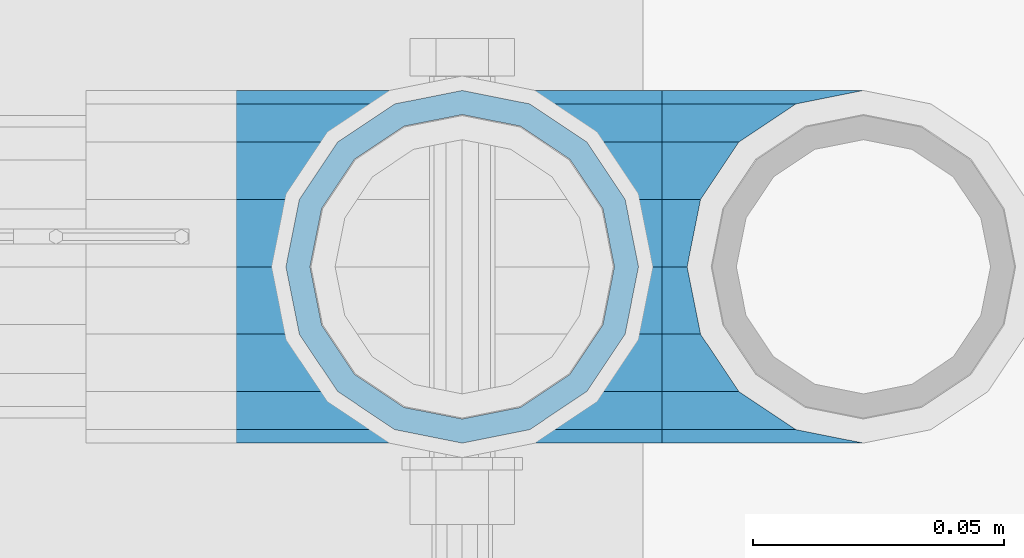
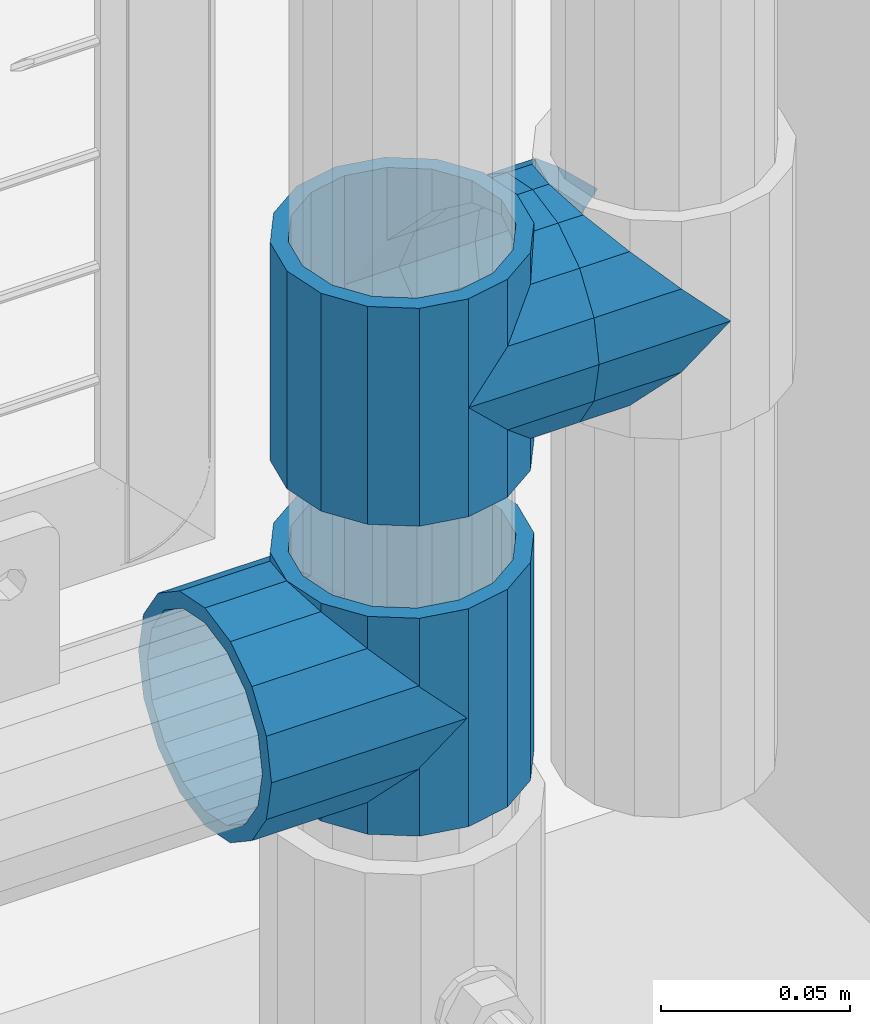
# One storey, part 173 of 257: 5 beams.
"""IFC2X3 building model written with IfcOpenShell, lengths in millimetres."""

from ifc_helpers import new_model, si_unit, frame, origin_with_axes, place, context, subcontext, project, spatial, faceted_brep, material, type_object, element, save


model = new_model("IFC2X3")

# Units and contexts
model_context = context("Model", 3, precision=1e-05, world=origin_with_axes())
body_context = subcontext(model_context, "Body", "Model", "MODEL_VIEW")
ifc_project = project(units=[si_unit("LENGTHUNIT", "METRE", prefix="MILLI"), si_unit("AREAUNIT", "SQUARE_METRE"), si_unit("VOLUMEUNIT", "CUBIC_METRE"), si_unit("MASSUNIT", "GRAM", prefix="KILO"), si_unit("TIMEUNIT", "SECOND"), si_unit("PLANEANGLEUNIT", "RADIAN"), si_unit("SOLIDANGLEUNIT", "STERADIAN"), si_unit("THERMODYNAMICTEMPERATUREUNIT", "DEGREE_CELSIUS"), si_unit("LUMINOUSINTENSITYUNIT", "LUMEN")], contexts=[model_context])

# Site, building, storey
site_placement = place(None, origin_with_axes())
site = spatial("IfcSite", under=ifc_project, at=site_placement, CompositionType="ELEMENT")
building_placement = place(site_placement, origin_with_axes())
building = spatial("IfcBuilding", under=site, at=building_placement, Name="Standard", CompositionType="ELEMENT")
storey_placement = place(building_placement, origin_with_axes())
storey = spatial("IfcBuildingStorey", under=building, at=storey_placement, Name="Undefined", CompositionType="ELEMENT", Elevation=0.0)

# Beams
ifc_material = material(Name="Misc_Undefined")
beam_type = type_object("IfcBeamType", PredefinedType="NOTDEFINED")
beam_1_placement = place(storey_placement, frame((58671.0, 10664.5, 298.670000000001), z_axis=(0.0, 1.0, 0.0), x_axis=(-1.0, 0.0, 0.0)))
element("IfcBeam", 1, at=beam_1_placement, inside=storey, type_object=beam_type, material=ifc_material, context=body_context, shape_type="Brep", body=[
    faceted_brep([(13.4513226476338, -13.4513226476329, -32.4743655677721), (13.4513226476338, 13.4513226476329, -32.4743655677721), (0.0, 0.0, -35.1499999999996), (24.8548033587067, -24.8548033587072, 24.8548033587067), (24.8548033587067, -16.3810424080013, 24.8548033587067), (27.122676859115, -21.4606908090117, 21.4606908090118), (32.4743655677739, -26.8123795176754, 13.4513226476338), (32.4743655677739, -32.4743655677717, 13.4513226476338), (32.8397438117172, -28.0397438117175, 11.6144421722802), (35.1500000000015, -30.35, 0.0), (35.1500000000015, -35.1499999999996, 0.0), (32.8397438117172, -28.0397438117175, -11.6144421722802), (32.4743655677739, -26.8123795176755, -13.4513226476338), (32.4743655677739, -32.4743655677717, -13.4513226476338), (27.1226768591005, -21.4606908090117, -21.4606908090118), (24.8548033587067, -16.3810424080045, -24.8548033587067), (24.8548033587067, -24.8548033587072, -24.8548033587067), (20.0882031229849, -11.6144421722805, -28.0397438117179), (16.6306603983685, 0.0, -30.3500000000004), (20.0882031229849, 11.6144421722805, -28.0397438117179), (24.8548033587067, 16.3810424080013, -24.8548033587067), (24.8548033587067, 24.8548033587072, -24.8548033587067), (32.4743655677739, 26.8123795176754, -13.4513226476338), (32.4743655677739, 32.4743655677717, -13.4513226476338), (27.1226768591005, 21.4606908090117, -21.4606908090118), (35.1500000000015, 30.35, 0.0), (35.1500000000015, 35.15, 0.0), (32.8397438117172, 28.0397438117175, -11.6144421722802), (32.8397438117172, 28.0397438117175, 11.6144421722802), (32.4743655677739, 26.8123795176755, 13.4513226476338), (32.4743655677739, 32.4743655677717, 13.4513226476338), (27.122676859115, 21.4606908090117, 21.4606908090118), (24.8548033587067, 16.3810424080013, 24.8548033587067), (24.8548033587067, 24.8548033587072, 24.8548033587067), (0.0, 0.0, 35.1499999999996), (13.4513226476338, 13.4513226476329, 32.4743655677721), (13.4513226476338, -13.4513226476329, 32.4743655677721), (20.0882031229849, 11.6144421722805, 28.0397438117179), (16.6306603983758, 0.0, 30.3500000000004), (20.0882031229849, -11.6144421722805, 28.0397438117179), (60.1500000000015, -35.15, 0.0), (60.1500000000015, -32.4743655677717, 13.4513226476338), (60.1500000000015, -24.8548033587072, 24.8548033587067), (60.1500000000015, -13.4513226476329, 32.4743655677721), (60.1500000000015, 0.0, 35.1499999999996), (60.1500000000015, -24.8548033587072, -24.8548033587067), (60.1500000000015, -32.4743655677717, -13.4513226476338), (60.1500000000015, -13.4513226476329, -32.4743655677721), (60.1500000000015, 0.0, -35.1499999999996), (60.1500000000015, 13.4513226476329, -32.4743655677721), (60.1500000000015, 24.8548033587072, -24.8548033587067), (60.1500000000015, 32.4743655677717, -13.4513226476338), (60.1500000000015, 35.15, 0.0), (60.1500000000015, 32.4743655677717, 13.4513226476338), (60.1500000000015, 24.8548033587072, 24.8548033587067), (60.1500000000015, 13.4513226476329, 32.4743655677721), (60.1500000000015, -21.4606908090117, 21.4606908090118), (60.1500000000015, -11.6144421722805, 28.0397438117179), (60.1500000000015, 0.0, 30.3500000000004), (60.1500000000015, 11.6144421722805, 28.0397438117179), (60.1500000000015, 21.4606908090117, 21.4606908090118), (60.1500000000015, 28.0397438117175, 11.6144421722802), (60.1500000000015, 30.35, 0.0), (60.1500000000015, 28.0397438117175, -11.6144421722802), (60.1500000000015, 21.4606908090117, -21.4606908090118), (60.1500000000015, 11.6144421722805, -28.0397438117179), (60.1500000000015, 0.0, -30.3500000000004), (60.1500000000015, -11.6144421722805, -28.0397438117179), (60.1500000000015, -21.4606908090117, -21.4606908090118), (60.1500000000015, -28.0397438117175, -11.6144421722802), (60.1500000000015, -30.35, 0.0), (60.1500000000015, -28.0397438117175, 11.6144421722802)], [[[0, 1, 2]], [[3, 4, 5, 6, 7]], [[7, 6, 8, 9, 10]], [[10, 9, 11, 12, 13]], [[13, 12, 14, 15, 16]], [[16, 15, 17, 18, 19, 20, 21, 1, 0]], [[22, 23, 21, 20, 24]], [[25, 26, 23, 22, 27]], [[28, 29, 30, 26, 25]], [[31, 32, 33, 30, 29]], [[34, 35, 36]], [[36, 35, 33, 32, 37, 38, 39, 4, 3]], [[40, 41, 7, 10]], [[41, 42, 3, 7]], [[42, 43, 36, 3]], [[43, 44, 34, 36]], [[45, 46, 13, 16]], [[47, 45, 16, 0]], [[48, 47, 0, 2]], [[49, 48, 2, 1]], [[50, 49, 1, 21]], [[51, 50, 21, 23]], [[52, 51, 23, 26]], [[53, 52, 26, 30]], [[54, 53, 30, 33]], [[55, 54, 33, 35]], [[44, 55, 35, 34]], [[46, 40, 10, 13]], [[45, 47, 48, 49, 50, 51, 52, 53, 54, 55, 44, 43, 42, 41, 40, 46], [56, 57, 58, 59, 60, 61, 62, 63, 64, 65, 66, 67, 68, 69, 70, 71]], [[59, 58, 38, 37]], [[60, 59, 37, 32, 31]], [[61, 60, 31, 29, 28]], [[62, 61, 28, 25]], [[63, 62, 25, 27]], [[24, 64, 63, 27, 22]], [[19, 65, 64, 24, 20]], [[66, 65, 19, 18]], [[67, 66, 18, 17]], [[68, 67, 17, 15, 14]], [[69, 68, 14, 12, 11]], [[70, 69, 11, 9]], [[71, 70, 9, 8]], [[5, 56, 71, 8, 6]], [[39, 57, 56, 5, 4]], [[58, 57, 39, 38]]]),
])
beam_2_placement = place(storey_placement, frame((58671.0, 10664.5, 333.820000000001), z_axis=(1.0, 0.0, 0.0), x_axis=(0.0, 0.0, -1.0)))
element("IfcBeam", 2, at=beam_2_placement, inside=storey, type_object=beam_type, material=ifc_material, context=body_context, shape_type="Brep", body=[
    faceted_brep([(56.6106908090114, 21.4606908090118, -27.1226768591077), (56.6106908090114, 21.4606908090118, -21.4606908090136), (46.7644421722801, 28.0397438117179, -11.6144421722784), (46.7644421722801, 28.0397438117179, -20.0882031229921), (51.5310424080039, 24.8548033587067, -24.8548033587067), (63.1897438117172, 11.6144421722802, -32.8397438117245), (63.1897438117172, 11.6144421722802, -28.0397438117143), (61.9623795176756, 13.4513226476338, -32.4743655677739), (65.4999999999997, 0.0, -35.1500000000015), (65.4999999999997, 0.0, -30.3499999999985), (63.1897438117172, -11.6144421722802, -32.8397438117245), (63.1897438117172, -11.6144421722802, -28.0397438117143), (61.9623795176756, -13.4513226476338, -32.4743655677739), (56.6106908090114, -21.4606908090118, -27.1226768591077), (56.6106908090114, -21.4606908090118, -21.4606908090136), (51.5310424080038, -24.8548033587067, -24.8548033587067), (46.7644421722801, -28.0397438117179, -20.0882031229849), (46.7644421722801, -28.0397438117179, -11.6144421722784), (35.1499999999996, -30.3500000000004, -16.6306603983685), (35.1500000000015, -30.35, 0.0), (23.5355578277191, -28.0397438117179, -20.0882031229849), (23.5355578277191, -28.0397438117179, -11.6144421722784), (13.6893091909879, -21.4606908090118, -27.1226768591077), (13.6893091909879, -21.4606908090118, -21.4606908090136), (18.7689575919987, -24.8548033587067, -24.8548033587067), (7.11025618828205, -11.6144421722802, -32.8397438117245), (7.11025618828205, -11.6144421722802, -28.0397438117143), (8.33762048232484, -13.4513226476338, -32.4743655677739), (4.79999999999961, 0.0, -35.1500000000015), (4.79999999999961, 0.0, -30.3499999999985), (7.11025618828211, 11.6144421722802, -32.8397438117245), (7.11025618828211, 11.6144421722802, -28.0397438117143), (8.3376204823237, 13.4513226476338, -32.4743655677739), (13.6893091909879, 21.4606908090118, -27.1226768591077), (13.6893091909879, 21.4606908090118, -21.4606908090136), (18.7689575919954, 24.8548033587067, -24.8548033587067), (23.5355578277192, 28.0397438117179, -20.0882031229921), (23.5355578277192, 28.0397438117179, -11.6144421722784), (35.1499999999996, 30.3500000000004, -16.6306603983758), (35.1500000000015, 30.35, 0.0), (0.0, 32.4743655677721, -13.4513226476338), (0.0, 35.1499999999996, 0.0), (70.2999999999993, 35.1499999999996, 0.0), (70.2999999999993, 32.4743655677721, -13.4513226476338), (0.0, 32.4743655677721, 13.4513226476338), (70.2999999999993, 32.4743655677721, 13.4513226476338), (0.0, 24.8548033587067, 24.8548033587067), (70.2999999999993, 24.8548033587067, 24.8548033587067), (0.0, 13.4513226476338, 32.4743655677739), (70.2999999999993, 13.4513226476338, 32.4743655677739), (0.0, 0.0, 35.1499999999996), (70.2999999999993, 0.0, 35.1500000000015), (0.0, -13.4513226476338, 32.4743655677739), (70.2999999999993, -13.4513226476338, 32.4743655677739), (0.0, -24.8548033587067, 24.8548033587067), (70.2999999999993, -24.8548033587067, 24.8548033587067), (0.0, -32.4743655677721, 13.4513226476338), (70.2999999999993, -32.4743655677721, 13.4513226476338), (0.0, -35.1499999999996, 0.0), (70.2999999999993, -35.1499999999996, 0.0), (70.2999999999993, -30.3500000000004, 0.0), (70.2999999999993, -28.0397438117179, -11.6144421722784), (70.2999999999993, -21.4606908090118, -21.4606908090136), (70.2999999999993, -11.6144421722802, -28.0397438117143), (70.2999999999993, 0.0, -30.3499999999985), (70.2999999999993, 11.6144421722802, -28.0397438117143), (70.2999999999993, 21.4606908090118, -21.4606908090136), (70.2999999999993, 28.0397438117179, -11.6144421722784), (0.0, -28.0397438117179, -11.6144421722784), (0.0, -30.3500000000004, 0.0), (0.0, -21.4606908090118, -21.4606908090136), (0.0, -11.6144421722802, -28.0397438117143), (0.0, 0.0, -30.3499999999985), (0.0, 11.6144421722802, -28.0397438117143), (0.0, 21.4606908090118, -21.4606908090136), (0.0, 28.0397438117179, -11.6144421722784), (0.0, 30.3500000000004, 0.0), (70.2999999999993, 30.3500000000004, 0.0), (0.0, 28.0397438117179, 11.6144421722784), (70.2999999999993, 28.0397438117179, 11.6144421722784), (0.0, 21.4606908090118, 21.4606908090136), (70.2999999999993, 21.4606908090118, 21.4606908090136), (0.0, 11.6144421722802, 28.0397438117143), (70.2999999999993, 11.6144421722802, 28.0397438117143), (0.0, 0.0, 30.3499999999985), (70.2999999999993, 0.0, 30.3499999999985), (0.0, -11.6144421722802, 28.0397438117143), (70.2999999999993, -11.6144421722802, 28.0397438117143), (0.0, -21.4606908090118, 21.4606908090136), (70.2999999999993, -21.4606908090118, 21.4606908090136), (0.0, -28.0397438117179, 11.6144421722784), (70.2999999999993, -28.0397438117179, 11.6144421722784), (70.2999999999993, -24.8548033587067, -24.8548033587067), (70.2999999999993, -13.4513226476338, -32.4743655677739), (70.2999999999993, 0.0, -35.1500000000015), (70.2999999999993, 13.4513226476338, -32.4743655677739), (70.2999999999993, 24.8548033587067, -24.8548033587067), (70.2999999999993, -32.4743655677721, -13.4513226476338), (0.0, -32.4743655677721, -13.4513226476338), (0.0, 24.8548033587067, -24.8548033587067), (0.0, 13.4513226476338, -32.4743655677739), (0.0, 0.0, -35.1499999999996), (0.0, -13.4513226476338, -32.4743655677739), (0.0, -24.8548033587067, -24.8548033587067)], [[[0, 1, 2, 3, 4]], [[5, 6, 1, 0, 7]], [[8, 9, 6, 5]], [[10, 11, 9, 8]], [[12, 13, 14, 11, 10]], [[15, 16, 17, 14, 13]], [[18, 19, 17, 16]], [[20, 21, 19, 18]], [[22, 23, 21, 20, 24]], [[25, 26, 23, 22, 27]], [[28, 29, 26, 25]], [[30, 31, 29, 28]], [[32, 33, 34, 31, 30]], [[35, 36, 37, 34, 33]], [[38, 39, 37, 36]], [[3, 2, 39, 38]], [[40, 41, 42, 43]], [[41, 44, 45, 42]], [[44, 46, 47, 45]], [[46, 48, 49, 47]], [[48, 50, 51, 49]], [[50, 52, 53, 51]], [[52, 54, 55, 53]], [[54, 56, 57, 55]], [[56, 58, 59, 57]], [[60, 61, 17, 19]], [[61, 62, 14, 17]], [[62, 63, 11, 14]], [[63, 64, 9, 11]], [[64, 65, 6, 9]], [[65, 66, 1, 6]], [[66, 67, 2, 1]], [[68, 69, 19, 21]], [[70, 68, 21, 23]], [[71, 70, 23, 26]], [[72, 71, 26, 29]], [[73, 72, 29, 31]], [[74, 73, 31, 34]], [[75, 74, 34, 37]], [[76, 75, 37, 39]], [[67, 77, 39, 2]], [[78, 76, 39, 77, 79]], [[80, 78, 79, 81]], [[82, 80, 81, 83]], [[84, 82, 83, 85]], [[86, 84, 85, 87]], [[88, 86, 87, 89]], [[90, 88, 89, 91]], [[19, 69, 90, 91, 60]], [[92, 93, 94, 95, 96, 43, 42, 45, 47, 49, 51, 53, 55, 57, 59, 97], [89, 87, 85, 83, 81, 79, 77, 67, 66, 65, 64, 63, 62, 61, 60, 91]], [[58, 98, 97, 59]], [[56, 54, 52, 50, 48, 46, 44, 41, 40, 99, 100, 101, 102, 103, 98, 58], [68, 70, 71, 72, 73, 74, 75, 76, 78, 80, 82, 84, 86, 88, 90, 69]], [[100, 99, 35, 33, 32]], [[101, 100, 32, 30, 28]], [[27, 102, 101, 28, 25]], [[24, 103, 102, 27, 22]], [[92, 97, 98, 103, 24, 20, 18, 16, 15]], [[93, 92, 15, 13, 12]], [[94, 93, 12, 10, 8]], [[7, 95, 94, 8, 5]], [[4, 96, 95, 7, 0]], [[38, 36, 35, 99, 40, 43, 96, 4, 3]]]),
])
beam_3_placement = place(storey_placement, frame((58671.0, 10664.5, 398.669999999998), z_axis=(0.0, -1.0, 0.0), x_axis=(1.0, 0.0, 0.0)))
element("IfcBeam", 3, at=beam_3_placement, inside=storey, type_object=beam_type, material=ifc_material, context=body_context, shape_type="Brep", body=[
    faceted_brep([(13.4513226476338, -13.4513226476329, -32.4743655677721), (13.4513226476338, 13.4513226476329, -32.4743655677721), (0.0, 0.0, -35.1499999999996), (27.122676859115, 21.4606908090117, 21.4606908090118), (24.8548033587067, 16.3810424080013, 24.8548033587067), (24.8548033587067, 24.8548033587072, 24.8548033587067), (32.4743655677739, 32.4743655677717, 13.4513226476338), (32.4743655677739, 26.8123795176755, 13.4513226476338), (0.0, 0.0, 35.1499999999996), (13.4513226476338, 13.4513226476329, 32.4743655677721), (13.4513226476338, -13.4513226476329, 32.4743655677721), (20.0882031229849, 11.6144421722805, 28.0397438117179), (16.6306603983758, 0.0, 30.3500000000004), (20.0882031229849, -11.6144421722805, 28.0397438117179), (24.8548033587067, -16.3810424080013, 24.8548033587067), (24.8548033587067, -24.8548033587072, 24.8548033587067), (27.122676859115, -21.4606908090117, 21.4606908090118), (32.4743655677739, -26.8123795176754, 13.4513226476338), (32.4743655677739, -32.4743655677717, 13.4513226476338), (32.8397438117172, -28.0397438117175, 11.6144421722802), (35.1500000000015, -30.35, 0.0), (35.1500000000015, -35.1499999999996, 0.0), (32.8397438117172, -28.0397438117175, -11.6144421722802), (32.4743655677739, -26.8123795176755, -13.4513226476338), (32.4743655677739, -32.4743655677717, -13.4513226476338), (27.1226768591005, -21.4606908090117, -21.4606908090118), (24.8548033587067, -16.3810424080045, -24.8548033587067), (24.8548033587067, -24.8548033587072, -24.8548033587067), (20.0882031229849, -11.6144421722805, -28.0397438117179), (16.6306603983685, 0.0, -30.3500000000004), (20.0882031229849, 11.6144421722805, -28.0397438117179), (24.8548033587067, 16.3810424080013, -24.8548033587067), (24.8548033587067, 24.8548033587072, -24.8548033587067), (32.4743655677739, 26.8123795176754, -13.4513226476338), (32.4743655677739, 32.4743655677717, -13.4513226476338), (27.1226768591005, 21.4606908090117, -21.4606908090118), (35.1500000000015, 30.35, 0.0), (35.1500000000015, 35.15, 0.0), (32.8397438117172, 28.0397438117175, -11.6144421722802), (32.8397438117172, 28.0397438117175, 11.6144421722802), (40.1500000000015, -35.15, 0.0), (40.1500000000015, -32.4743655677717, 13.4513226476338), (40.1500000000015, -24.8548033587072, 24.8548033587067), (40.1500000000015, -13.4513226476329, 32.4743655677721), (40.1500000000015, 0.0, 35.1499999999996), (40.1500000000015, 13.4513226476329, 32.4743655677721), (40.1500000000015, 24.8548033587072, 24.8548033587067), (40.1500000000015, 32.4743655677717, 13.4513226476338), (40.1500000000015, 35.15, 0.0), (40.1500000000015, -24.8548033587072, -24.8548033587067), (40.1500000000015, -32.4743655677717, -13.4513226476338), (40.1500000000015, -13.4513226476329, -32.4743655677721), (40.1500000000015, 0.0, -35.1499999999996), (40.1500000000015, 13.4513226476329, -32.4743655677721), (40.1500000000015, 24.8548033587072, -24.8548033587067), (40.1500000000015, 32.4743655677717, -13.4513226476338), (40.1500000000015, -21.4606908090117, 21.4606908090118), (40.1500000000015, -11.6144421722805, 28.0397438117179), (40.1500000000015, 0.0, 30.3500000000004), (40.1500000000015, 11.6144421722805, 28.0397438117179), (40.1500000000015, 21.4606908090117, 21.4606908090118), (40.1500000000015, 28.0397438117175, 11.6144421722802), (40.1500000000015, 30.35, 0.0), (40.1500000000015, 28.0397438117175, -11.6144421722802), (40.1500000000015, 21.4606908090117, -21.4606908090118), (40.1500000000015, 11.6144421722805, -28.0397438117179), (40.1500000000015, 0.0, -30.3500000000004), (40.1500000000015, -11.6144421722805, -28.0397438117179), (40.1500000000015, -21.4606908090117, -21.4606908090118), (40.1500000000015, -28.0397438117175, -11.6144421722802), (40.1500000000015, -30.35, 0.0), (40.1500000000015, -28.0397438117175, 11.6144421722802)], [[[0, 1, 2]], [[3, 4, 5, 6, 7]], [[8, 9, 10]], [[10, 9, 5, 4, 11, 12, 13, 14, 15]], [[15, 14, 16, 17, 18]], [[18, 17, 19, 20, 21]], [[21, 20, 22, 23, 24]], [[24, 23, 25, 26, 27]], [[27, 26, 28, 29, 30, 31, 32, 1, 0]], [[33, 34, 32, 31, 35]], [[36, 37, 34, 33, 38]], [[39, 7, 6, 37, 36]], [[40, 41, 18, 21]], [[41, 42, 15, 18]], [[42, 43, 10, 15]], [[43, 44, 8, 10]], [[44, 45, 9, 8]], [[45, 46, 5, 9]], [[46, 47, 6, 5]], [[47, 48, 37, 6]], [[49, 50, 24, 27]], [[51, 49, 27, 0]], [[52, 51, 0, 2]], [[53, 52, 2, 1]], [[54, 53, 1, 32]], [[55, 54, 32, 34]], [[48, 55, 34, 37]], [[50, 40, 21, 24]], [[49, 51, 52, 53, 54, 55, 48, 47, 46, 45, 44, 43, 42, 41, 40, 50], [56, 57, 58, 59, 60, 61, 62, 63, 64, 65, 66, 67, 68, 69, 70, 71]], [[63, 62, 36, 38]], [[35, 64, 63, 38, 33]], [[30, 65, 64, 35, 31]], [[66, 65, 30, 29]], [[67, 66, 29, 28]], [[68, 67, 28, 26, 25]], [[69, 68, 25, 23, 22]], [[70, 69, 22, 20]], [[71, 70, 20, 19]], [[16, 56, 71, 19, 17]], [[13, 57, 56, 16, 14]], [[58, 57, 13, 12]], [[59, 58, 12, 11]], [[60, 59, 11, 4, 3]], [[61, 60, 3, 7, 39]], [[62, 61, 39, 36]]]),
])
beam_4_placement = place(storey_placement, frame((58751.0, 10664.5, 398.669999999998), z_axis=(0.0, 1.0, 0.0), x_axis=(-1.0, 0.0, 0.0)))
element("IfcBeam", 4, at=beam_4_placement, inside=storey, type_object=beam_type, material=ifc_material, context=body_context, shape_type="Brep", body=[
    faceted_brep([(13.4513226476338, -13.4513226476329, -32.4743655677721), (13.4513226476338, 13.4513226476329, -32.4743655677721), (0.0, 0.0, -35.1499999999996), (24.8548033587067, -24.8548033587072, 24.8548033587067), (24.8548033587067, -16.3810424080013, 24.8548033587067), (27.122676859115, -21.4606908090117, 21.4606908090118), (32.4743655677739, -26.8123795176754, 13.4513226476338), (32.4743655677739, -32.4743655677717, 13.4513226476338), (32.8397438117172, -28.0397438117175, 11.6144421722802), (35.1500000000015, -30.35, 0.0), (35.1500000000015, -35.1499999999996, 0.0), (32.8397438117172, -28.0397438117175, -11.6144421722802), (32.4743655677739, -26.8123795176755, -13.4513226476338), (32.4743655677739, -32.4743655677717, -13.4513226476338), (27.1226768591005, -21.4606908090117, -21.4606908090118), (24.8548033587067, -16.3810424080045, -24.8548033587067), (24.8548033587067, -24.8548033587072, -24.8548033587067), (20.0882031229849, -11.6144421722805, -28.0397438117179), (16.6306603983685, 0.0, -30.3500000000004), (20.0882031229849, 11.6144421722805, -28.0397438117179), (24.8548033587067, 16.3810424080013, -24.8548033587067), (24.8548033587067, 24.8548033587072, -24.8548033587067), (32.4743655677739, 26.8123795176754, -13.4513226476338), (32.4743655677739, 32.4743655677717, -13.4513226476338), (27.1226768591005, 21.4606908090117, -21.4606908090118), (35.1500000000015, 30.35, 0.0), (35.1500000000015, 35.15, 0.0), (32.8397438117172, 28.0397438117175, -11.6144421722802), (32.8397438117172, 28.0397438117175, 11.6144421722802), (32.4743655677739, 26.8123795176755, 13.4513226476338), (32.4743655677739, 32.4743655677717, 13.4513226476338), (27.122676859115, 21.4606908090117, 21.4606908090118), (24.8548033587067, 16.3810424080013, 24.8548033587067), (24.8548033587067, 24.8548033587072, 24.8548033587067), (0.0, 0.0, 35.1499999999996), (13.4513226476338, 13.4513226476329, 32.4743655677721), (13.4513226476338, -13.4513226476329, 32.4743655677721), (20.0882031229849, 11.6144421722805, 28.0397438117179), (16.6306603983758, 0.0, 30.3500000000004), (20.0882031229849, -11.6144421722805, 28.0397438117179), (40.1500000000015, -35.15, 0.0), (40.1500000000015, -32.4743655677717, 13.4513226476338), (40.1500000000015, -24.8548033587072, 24.8548033587067), (40.1500000000015, -13.4513226476329, 32.4743655677721), (40.1500000000015, 0.0, 35.1499999999996), (40.1500000000015, -24.8548033587072, -24.8548033587067), (40.1500000000015, -32.4743655677717, -13.4513226476338), (40.1500000000015, -13.4513226476329, -32.4743655677721), (40.1500000000015, 0.0, -35.1499999999996), (40.1500000000015, 13.4513226476329, -32.4743655677721), (40.1500000000015, 24.8548033587072, -24.8548033587067), (40.1500000000015, 32.4743655677717, -13.4513226476338), (40.1500000000015, 35.15, 0.0), (40.1500000000015, 32.4743655677717, 13.4513226476338), (40.1500000000015, 24.8548033587072, 24.8548033587067), (40.1500000000015, 13.4513226476329, 32.4743655677721), (40.1500000000015, -21.4606908090117, 21.4606908090118), (40.1500000000015, -11.6144421722805, 28.0397438117179), (40.1500000000015, 0.0, 30.3500000000004), (40.1500000000015, 11.6144421722805, 28.0397438117179), (40.1500000000015, 21.4606908090117, 21.4606908090118), (40.1500000000015, 28.0397438117175, 11.6144421722802), (40.1500000000015, 30.35, 0.0), (40.1500000000015, 28.0397438117175, -11.6144421722802), (40.1500000000015, 21.4606908090117, -21.4606908090118), (40.1500000000015, 11.6144421722805, -28.0397438117179), (40.1500000000015, 0.0, -30.3500000000004), (40.1500000000015, -11.6144421722805, -28.0397438117179), (40.1500000000015, -21.4606908090117, -21.4606908090118), (40.1500000000015, -28.0397438117175, -11.6144421722802), (40.1500000000015, -30.35, 0.0), (40.1500000000015, -28.0397438117175, 11.6144421722802)], [[[0, 1, 2]], [[3, 4, 5, 6, 7]], [[7, 6, 8, 9, 10]], [[10, 9, 11, 12, 13]], [[13, 12, 14, 15, 16]], [[16, 15, 17, 18, 19, 20, 21, 1, 0]], [[22, 23, 21, 20, 24]], [[25, 26, 23, 22, 27]], [[28, 29, 30, 26, 25]], [[31, 32, 33, 30, 29]], [[34, 35, 36]], [[36, 35, 33, 32, 37, 38, 39, 4, 3]], [[40, 41, 7, 10]], [[41, 42, 3, 7]], [[42, 43, 36, 3]], [[43, 44, 34, 36]], [[45, 46, 13, 16]], [[47, 45, 16, 0]], [[48, 47, 0, 2]], [[49, 48, 2, 1]], [[50, 49, 1, 21]], [[51, 50, 21, 23]], [[52, 51, 23, 26]], [[53, 52, 26, 30]], [[54, 53, 30, 33]], [[55, 54, 33, 35]], [[44, 55, 35, 34]], [[46, 40, 10, 13]], [[45, 47, 48, 49, 50, 51, 52, 53, 54, 55, 44, 43, 42, 41, 40, 46], [56, 57, 58, 59, 60, 61, 62, 63, 64, 65, 66, 67, 68, 69, 70, 71]], [[59, 58, 38, 37]], [[60, 59, 37, 32, 31]], [[61, 60, 31, 29, 28]], [[62, 61, 28, 25]], [[63, 62, 25, 27]], [[24, 64, 63, 27, 22]], [[19, 65, 64, 24, 20]], [[66, 65, 19, 18]], [[67, 66, 18, 17]], [[68, 67, 17, 15, 14]], [[69, 68, 14, 12, 11]], [[70, 69, 11, 9]], [[71, 70, 9, 8]], [[5, 56, 71, 8, 6]], [[39, 57, 56, 5, 4]], [[58, 57, 39, 38]]]),
])
beam_5_placement = place(storey_placement, frame((58671.0, 10664.5, 433.819999999998), z_axis=(-1.0, 0.0, 0.0), x_axis=(0.0, 0.0, -1.0)))
element("IfcBeam", 5, at=beam_5_placement, inside=storey, type_object=beam_type, material=ifc_material, context=body_context, shape_type="Brep", body=[
    faceted_brep([(7.11025618828205, -11.6144421722802, -32.8397438117245), (7.11025618828205, -11.6144421722802, -28.0397438117143), (13.6893091909879, -21.4606908090118, -21.4606908090136), (13.6893091909879, -21.4606908090118, -27.1226768591077), (8.33762048232484, -13.4513226476338, -32.4743655677739), (23.5355578277191, -28.0397438117179, -11.6144421722784), (23.5355578277191, -28.0397438117179, -20.0882031229849), (18.7689575919987, -24.8548033587067, -24.8548033587067), (35.1500000000015, -30.35, 0.0), (35.1499999999996, -30.3500000000004, -16.6306603983685), (46.7644421722801, -28.0397438117179, -11.6144421722784), (46.7644421722801, -28.0397438117179, -20.0882031229849), (51.5310424080038, -24.8548033587067, -24.8548033587067), (56.6106908090114, -21.4606908090118, -21.4606908090136), (56.6106908090114, -21.4606908090118, -27.1226768591077), (61.9623795176756, -13.4513226476338, -32.4743655677739), (63.1897438117172, -11.6144421722802, -28.0397438117143), (63.1897438117172, -11.6144421722802, -32.8397438117245), (65.4999999999997, 0.0, -30.3499999999985), (65.4999999999997, 0.0, -35.1500000000015), (63.1897438117172, 11.6144421722802, -28.0397438117143), (63.1897438117172, 11.6144421722802, -32.8397438117245), (56.6106908090114, 21.4606908090118, -21.4606908090136), (56.6106908090114, 21.4606908090118, -27.1226768591077), (61.9623795176756, 13.4513226476338, -32.4743655677739), (46.7644421722801, 28.0397438117179, -11.6144421722784), (46.7644421722801, 28.0397438117179, -20.0882031229921), (51.5310424080039, 24.8548033587067, -24.8548033587067), (35.1500000000015, 30.35, 0.0), (35.1499999999996, 30.3500000000004, -16.6306603983758), (23.5355578277192, 28.0397438117179, -11.6144421722784), (23.5355578277192, 28.0397438117179, -20.0882031229921), (18.7689575919954, 24.8548033587067, -24.8548033587067), (13.6893091909879, 21.4606908090118, -21.4606908090136), (13.6893091909879, 21.4606908090118, -27.1226768591077), (8.3376204823237, 13.4513226476338, -32.4743655677739), (7.11025618828211, 11.6144421722802, -28.0397438117143), (7.11025618828211, 11.6144421722802, -32.8397438117245), (4.79999999999961, 0.0, -30.3499999999985), (4.79999999999961, 0.0, -35.1500000000015), (0.0, 21.4606908090118, 21.4606908090136), (0.0, 28.0397438117179, 11.6144421722784), (70.2999999999993, 28.0397438117179, 11.6144421722784), (70.2999999999993, 21.4606908090118, 21.4606908090136), (0.0, 11.6144421722802, 28.0397438117143), (70.2999999999993, 11.6144421722802, 28.0397438117143), (0.0, 0.0, 30.3499999999985), (70.2999999999993, 0.0, 30.3499999999985), (0.0, -11.6144421722802, 28.0397438117143), (70.2999999999993, -11.6144421722802, 28.0397438117143), (0.0, -21.4606908090118, 21.4606908090136), (70.2999999999993, -21.4606908090118, 21.4606908090136), (0.0, -28.0397438117179, 11.6144421722784), (70.2999999999993, -28.0397438117179, 11.6144421722784), (0.0, -24.8548033587067, -24.8548033587067), (0.0, -13.4513226476338, -32.4743655677739), (0.0, 0.0, -35.1499999999996), (0.0, -32.4743655677721, 13.4513226476338), (0.0, -35.1499999999996, 0.0), (70.2999999999993, -35.1499999999996, 0.0), (70.2999999999993, -32.4743655677721, 13.4513226476338), (0.0, -24.8548033587067, 24.8548033587067), (70.2999999999993, -24.8548033587067, 24.8548033587067), (0.0, -13.4513226476338, 32.4743655677739), (70.2999999999993, -13.4513226476338, 32.4743655677739), (0.0, 0.0, 35.1499999999996), (70.2999999999993, 0.0, 35.1500000000015), (0.0, 13.4513226476338, 32.4743655677739), (70.2999999999993, 13.4513226476338, 32.4743655677739), (0.0, 24.8548033587067, 24.8548033587067), (70.2999999999993, 24.8548033587067, 24.8548033587067), (0.0, 32.4743655677721, 13.4513226476338), (70.2999999999993, 32.4743655677721, 13.4513226476338), (0.0, 35.1499999999996, 0.0), (70.2999999999993, 35.1499999999996, 0.0), (0.0, 32.4743655677721, -13.4513226476338), (70.2999999999993, 32.4743655677721, -13.4513226476338), (70.2999999999993, -13.4513226476338, -32.4743655677739), (70.2999999999993, -24.8548033587067, -24.8548033587067), (70.2999999999993, 0.0, -35.1500000000015), (70.2999999999993, 13.4513226476338, -32.4743655677739), (70.2999999999993, 24.8548033587067, -24.8548033587067), (0.0, 24.8548033587067, -24.8548033587067), (0.0, 13.4513226476338, -32.4743655677739), (70.2999999999993, -32.4743655677721, -13.4513226476338), (0.0, -32.4743655677721, -13.4513226476338), (0.0, -28.0397438117179, -11.6144421722784), (0.0, -21.4606908090118, -21.4606908090136), (0.0, -11.6144421722802, -28.0397438117143), (0.0, 0.0, -30.3499999999985), (0.0, 11.6144421722802, -28.0397438117143), (0.0, 21.4606908090118, -21.4606908090136), (0.0, 28.0397438117179, -11.6144421722784), (0.0, 30.3500000000004, 0.0), (0.0, -30.3500000000004, 0.0), (70.2999999999993, 30.3500000000004, 0.0), (70.2999999999993, 28.0397438117179, -11.6144421722784), (70.2999999999993, 21.4606908090118, -21.4606908090136), (70.2999999999993, 11.6144421722802, -28.0397438117143), (70.2999999999993, 0.0, -30.3499999999985), (70.2999999999993, -11.6144421722802, -28.0397438117143), (70.2999999999993, -21.4606908090118, -21.4606908090136), (70.2999999999993, -28.0397438117179, -11.6144421722784), (70.2999999999993, -30.3500000000004, 0.0)], [[[0, 1, 2, 3, 4]], [[3, 2, 5, 6, 7]], [[6, 5, 8, 9]], [[9, 8, 10, 11]], [[12, 11, 10, 13, 14]], [[15, 14, 13, 16, 17]], [[17, 16, 18, 19]], [[19, 18, 20, 21]], [[21, 20, 22, 23, 24]], [[23, 22, 25, 26, 27]], [[26, 25, 28, 29]], [[29, 28, 30, 31]], [[32, 31, 30, 33, 34]], [[35, 34, 33, 36, 37]], [[37, 36, 38, 39]], [[39, 38, 1, 0]], [[40, 41, 42, 43]], [[44, 40, 43, 45]], [[46, 44, 45, 47]], [[48, 46, 47, 49]], [[50, 48, 49, 51]], [[52, 50, 51, 53]], [[7, 54, 55, 4, 3]], [[4, 55, 56, 39, 0]], [[57, 58, 59, 60]], [[61, 57, 60, 62]], [[63, 61, 62, 64]], [[65, 63, 64, 66]], [[67, 65, 66, 68]], [[69, 67, 68, 70]], [[71, 69, 70, 72]], [[73, 71, 72, 74]], [[75, 73, 74, 76]], [[77, 78, 12, 14, 15]], [[79, 77, 15, 17, 19]], [[24, 80, 79, 19, 21]], [[27, 81, 80, 24, 23]], [[29, 31, 32, 82, 75, 76, 81, 27, 26]], [[83, 82, 32, 34, 35]], [[56, 83, 35, 37, 39]], [[78, 84, 85, 54, 7, 6, 9, 11, 12]], [[58, 85, 84, 59]], [[57, 61, 63, 65, 67, 69, 71, 73, 75, 82, 83, 56, 55, 54, 85, 58], [86, 87, 88, 89, 90, 91, 92, 93, 41, 40, 44, 46, 48, 50, 52, 94]], [[90, 89, 38, 36]], [[91, 90, 36, 33]], [[92, 91, 33, 30]], [[93, 92, 30, 28]], [[41, 93, 28, 95, 42]], [[96, 95, 28, 25]], [[97, 96, 25, 22]], [[98, 97, 22, 20]], [[99, 98, 20, 18]], [[100, 99, 18, 16]], [[101, 100, 16, 13]], [[102, 101, 13, 10]], [[103, 102, 10, 8]], [[78, 77, 79, 80, 81, 76, 74, 72, 70, 68, 66, 64, 62, 60, 59, 84], [51, 49, 47, 45, 43, 42, 95, 96, 97, 98, 99, 100, 101, 102, 103, 53]], [[8, 94, 52, 53, 103]], [[86, 94, 8, 5]], [[87, 86, 5, 2]], [[88, 87, 2, 1]], [[89, 88, 1, 38]]]),
])

save(model, "model.ifc")
